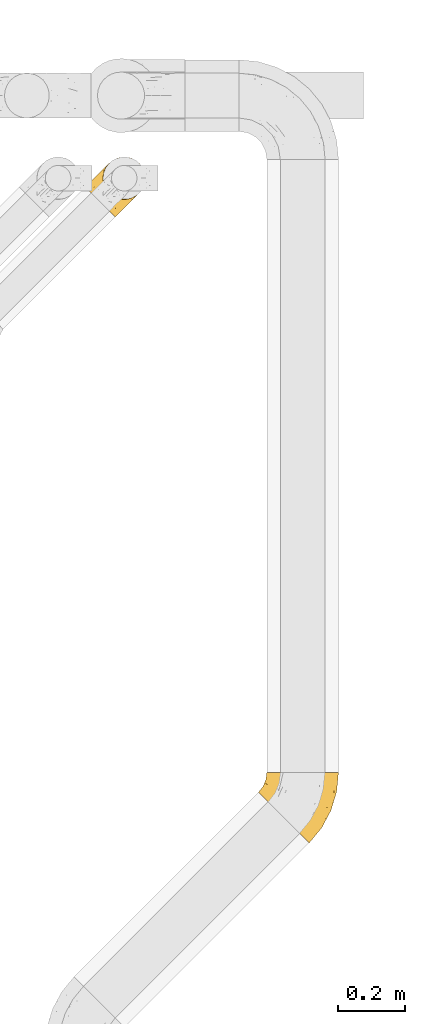
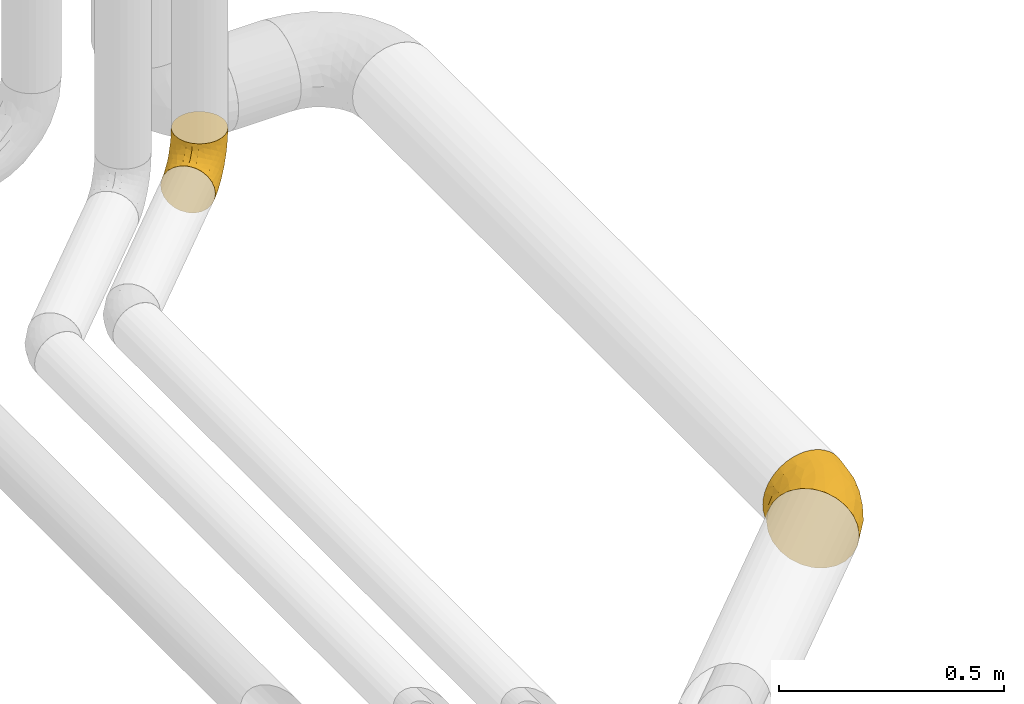
# One storey, part 36 of 93: 2 coverings.
"""IFC2X3 building model written with IfcOpenShell, lengths in millimetres."""

from ifc_helpers import new_model, entity, si_unit, converted_unit, derived_unit, direction, frame, origin, place, context, subcontext, project, spatial, faceted_brep, element, save


model = new_model("IFC2X3")

# Units and contexts
model_context = context("Model", 3, precision=0.01, world=origin(), true_north=direction((6.12303176911189e-17, 1.0)))
body_context = subcontext(model_context, "Body", "Model", "MODEL_VIEW")
ifc_project = project(units=[si_unit("LENGTHUNIT", "METRE", prefix="MILLI"), si_unit("AREAUNIT", "SQUARE_METRE"), si_unit("VOLUMEUNIT", "CUBIC_METRE"), converted_unit("PLANEANGLEUNIT", "DEGREE", entity("IfcRatioMeasure", 0.0174532925199433), si_unit("PLANEANGLEUNIT", "RADIAN"), dimensions=[0, 0, 0, 0, 0, 0, 0]), si_unit("MASSUNIT", "GRAM", prefix="KILO"), derived_unit("MASSDENSITYUNIT", [(si_unit("MASSUNIT", "GRAM", prefix="KILO"), 1), (si_unit("LENGTHUNIT", "METRE"), -3)]), derived_unit("MOMENTOFINERTIAUNIT", [(si_unit("LENGTHUNIT", "METRE"), 4)]), si_unit("TIMEUNIT", "SECOND"), si_unit("FREQUENCYUNIT", "HERTZ"), si_unit("THERMODYNAMICTEMPERATUREUNIT", "DEGREE_CELSIUS"), derived_unit("THERMALTRANSMITTANCEUNIT", [(si_unit("MASSUNIT", "GRAM", prefix="KILO"), 1), (si_unit("THERMODYNAMICTEMPERATUREUNIT", "KELVIN"), -1), (si_unit("TIMEUNIT", "SECOND"), -3)]), derived_unit("VOLUMETRICFLOWRATEUNIT", [(si_unit("LENGTHUNIT", "METRE"), 3), (si_unit("TIMEUNIT", "SECOND"), -1)]), derived_unit("MASSFLOWRATEUNIT", [(si_unit("MASSUNIT", "GRAM", prefix="KILO"), 1), (si_unit("TIMEUNIT", "SECOND"), -1)]), derived_unit("ROTATIONALFREQUENCYUNIT", [(si_unit("TIMEUNIT", "SECOND"), -1)]), si_unit("ELECTRICCURRENTUNIT", "AMPERE"), si_unit("ELECTRICVOLTAGEUNIT", "VOLT"), si_unit("POWERUNIT", "WATT"), si_unit("FORCEUNIT", "NEWTON", prefix="KILO"), si_unit("ILLUMINANCEUNIT", "LUX"), si_unit("LUMINOUSFLUXUNIT", "LUMEN"), si_unit("LUMINOUSINTENSITYUNIT", "CANDELA"), derived_unit("USERDEFINED", [(si_unit("MASSUNIT", "GRAM", prefix="KILO"), -1), (si_unit("LENGTHUNIT", "METRE"), -2), (si_unit("TIMEUNIT", "SECOND"), 3), (si_unit("LUMINOUSFLUXUNIT", "LUMEN"), 1)]), derived_unit("LINEARVELOCITYUNIT", [(si_unit("LENGTHUNIT", "METRE"), 1), (si_unit("TIMEUNIT", "SECOND"), -1)]), si_unit("PRESSUREUNIT", "PASCAL"), derived_unit("USERDEFINED", [(si_unit("LENGTHUNIT", "METRE"), -2), (si_unit("MASSUNIT", "GRAM", prefix="KILO"), 1), (si_unit("TIMEUNIT", "SECOND"), -2)]), derived_unit("LINEARFORCEUNIT", [(si_unit("MASSUNIT", "GRAM", prefix="KILO"), 1), (si_unit("LENGTHUNIT", "METRE"), 1), (si_unit("TIMEUNIT", "SECOND"), -2), (si_unit("LENGTHUNIT", "METRE"), -1)]), derived_unit("PLANARFORCEUNIT", [(si_unit("MASSUNIT", "GRAM", prefix="KILO"), 1), (si_unit("LENGTHUNIT", "METRE"), 1), (si_unit("TIMEUNIT", "SECOND"), -2), (si_unit("LENGTHUNIT", "METRE"), -2)])], contexts=[model_context])

# Site, building, storey
site_placement = place(None, origin())
site = spatial("IfcSite", under=ifc_project, at=site_placement, CompositionType="ELEMENT")
building_placement = place(site_placement, origin())
building = spatial("IfcBuilding", under=site, at=building_placement, CompositionType="ELEMENT")
storey_placement = place(building_placement, frame((0.0, 0.0, -4200.0)))
storey = spatial("IfcBuildingStorey", under=building, at=storey_placement, CompositionType="ELEMENT", Elevation=-4200.0)

# Coverings
covering_1_placement = place(storey_placement, frame((25506.57, 10093.02, 2891.9)))
element("IfcCovering", 1, at=covering_1_placement, inside=storey, Name=":ADSK_", ObjectType=":ADSK_", PredefinedType="INSULATION", context=body_context, shape_type="Brep", body=[
    faceted_brep([(37.66, 211.25, 156.45), (46.39, 211.25, 170.7), (57.25, 211.25, 183.4), (69.95, 211.25, 194.26), (84.2, 211.25, 202.99), (99.64, 211.25, 209.38), (115.89, 211.25, 213.28), (132.55, 211.25, 214.6), (149.22, 211.25, 213.28), (165.47, 211.25, 209.38), (180.91, 211.25, 202.99), (195.15, 211.25, 194.25), (207.86, 211.25, 183.4), (218.71, 211.25, 170.69), (227.44, 211.25, 156.45), (233.84, 211.25, 141.01), (237.74, 211.25, 124.76), (239.05, 211.25, 108.1), (237.74, 211.25, 91.43), (233.84, 211.25, 75.18), (227.44, 211.25, 59.74), (218.71, 211.25, 45.49), (207.86, 211.25, 32.79), (195.15, 211.25, 21.93), (180.9, 211.25, 13.2), (165.46, 211.25, 6.81), (149.21, 211.25, 2.91), (132.55, 211.25, 1.6), (115.89, 211.25, 2.91), (99.64, 211.25, 6.81), (84.2, 211.25, 13.21), (69.95, 211.25, 21.94), (57.24, 211.25, 32.79), (46.39, 211.25, 45.5), (37.66, 211.25, 59.74), (31.26, 211.25, 75.18), (27.36, 211.25, 91.43), (26.05, 211.25, 108.1), (27.36, 211.25, 124.76), (31.27, 211.25, 141.01), (1.6, 152.21, 108.1), (4.16, 149.64, 80.53), (11.68, 142.12, 54.85), (23.65, 130.15, 32.79), (39.25, 114.56, 15.86), (57.41, 96.39, 5.22), (76.9, 76.9, 1.6), (96.39, 57.41, 5.22), (114.56, 39.25, 15.86), (130.15, 23.65, 32.79), (142.12, 11.68, 54.85), (149.64, 4.16, 80.53), (152.21, 1.6, 108.1), (149.64, 4.16, 135.66), (142.12, 11.68, 161.35), (130.15, 23.65, 183.4), (114.56, 39.25, 200.33), (96.39, 57.41, 210.97), (76.9, 76.9, 214.6), (57.41, 96.39, 210.97), (39.25, 114.56, 200.33), (23.65, 130.15, 183.4), (11.68, 142.12, 161.35), (4.16, 149.64, 135.66), (200.63, 72.7, 135.49), (189.08, 46.53, 108.1), (216.48, 97.79, 108.1), (225.14, 151.09, 147.54), (224.66, 126.02, 127.59), (203.85, 103.93, 160.91), (184.62, 95.96, 180.48), (174.13, 56.47, 167.28), (208.26, 151.24, 175.57), (188.26, 163.53, 195.88), (145.0, 147.35, 212.24), (122.46, 102.43, 212.65), (144.65, 102.26, 206.95), (169.75, 156.96, 205.26), (118.09, 138.54, 214.6), (100.53, 105.69, 214.6), (153.71, 66.85, 191.83), (128.9, 174.19, 214.6), (233.35, 153.41, 108.1), (173.63, 116.59, 196.28), (75.61, 126.11, 209.66), (100.85, 155.5, 212.26), (78.92, 160.56, 204.85), (53.32, 141.97, 196.53), (65.14, 186.68, 192.48), (41.13, 188.55, 166.83), (49.52, 171.02, 182.99), (96.52, 181.83, 209.27), (32.64, 151.73, 176.02), (21.83, 178.42, 130.14), (23.21, 189.64, 108.1), (14.86, 169.5, 108.1), (28.58, 174.54, 153.23), (63.21, 165.87, 195.33), (21.83, 178.42, 86.05), (68.93, 185.87, 20.86), (62.27, 161.66, 20.39), (51.64, 183.46, 34.97), (82.06, 152.23, 8.81), (96.93, 173.91, 6.26), (28.58, 174.54, 62.96), (38.25, 155.81, 37.12), (48.99, 137.53, 20.47), (96.59, 137.92, 3.38), (118.09, 138.54, 1.6), (76.16, 126.61, 6.47), (100.53, 105.69, 1.6), (128.9, 174.19, 1.6), (131.79, 112.92, 4.17), (220.0, 129.96, 69.12), (195.21, 106.6, 41.95), (212.72, 157.34, 44.59), (168.72, 53.94, 44.6), (132.03, 76.09, 10.55), (154.58, 160.77, 5.33), (201.13, 72.5, 82.82), (162.25, 77.86, 25.33), (179.31, 48.81, 64.4), (224.88, 125.92, 89.94), (196.95, 152.51, 28.79), (173.66, 165.09, 11.88), (159.49, 119.29, 11.86)], [[[0, 1, 2, 3, 4, 5, 6, 7, 8, 9, 10, 11, 12, 13, 14, 15, 16, 17, 18, 19, 20, 21, 22, 23, 24, 25, 26, 27, 28, 29, 30, 31, 32, 33, 34, 35, 36, 37, 38, 39]], [[40, 41, 42, 43, 44, 45, 46, 47, 48, 49, 50, 51, 52, 53, 54, 55, 56, 57, 58, 59, 60, 61, 62, 63]], [[64, 65, 66]], [[65, 53, 52]], [[67, 68, 16]], [[67, 69, 64]], [[69, 70, 71]], [[68, 64, 66]], [[67, 72, 69]], [[69, 72, 70]], [[72, 73, 70]], [[74, 9, 8]], [[75, 58, 57]], [[76, 77, 74]], [[74, 77, 9]], [[78, 79, 75]], [[55, 71, 80]], [[76, 74, 75]], [[81, 78, 74]], [[73, 12, 11]], [[80, 76, 56]], [[13, 12, 72]], [[68, 66, 82]], [[76, 83, 77]], [[72, 67, 13]], [[67, 14, 13]], [[64, 68, 67]], [[73, 72, 12]], [[16, 15, 67]], [[16, 82, 17]], [[76, 80, 83]], [[64, 71, 54]], [[54, 53, 64]], [[71, 70, 80]], [[74, 8, 81]], [[7, 81, 8]], [[74, 78, 75]], [[53, 65, 64]], [[77, 10, 9]], [[83, 73, 77]], [[71, 55, 54]], [[80, 70, 83]], [[10, 77, 73]], [[56, 76, 57]], [[16, 68, 82]], [[15, 14, 67]], [[55, 80, 56]], [[64, 69, 71]], [[73, 83, 70]], [[10, 73, 11]], [[58, 75, 79]], [[57, 76, 75]], [[78, 84, 79]], [[59, 58, 79]], [[85, 84, 78]], [[84, 86, 87]], [[59, 79, 84]], [[60, 87, 61]], [[84, 85, 86]], [[88, 89, 90]], [[85, 91, 86]], [[61, 92, 62]], [[93, 94, 95]], [[38, 93, 39]], [[84, 87, 60]], [[95, 40, 63]], [[63, 96, 93]], [[63, 93, 95]], [[62, 96, 63]], [[97, 88, 90]], [[81, 91, 85]], [[81, 85, 78]], [[4, 88, 91]], [[3, 88, 4]], [[6, 91, 81]], [[89, 88, 2]], [[93, 96, 39]], [[5, 91, 6]], [[7, 6, 81]], [[91, 88, 86]], [[92, 89, 96]], [[97, 86, 88]], [[89, 2, 1]], [[37, 94, 38]], [[93, 38, 94]], [[60, 59, 84]], [[90, 92, 87]], [[0, 89, 1]], [[2, 88, 3]], [[39, 89, 0]], [[89, 39, 96]], [[96, 62, 92]], [[92, 90, 89]], [[5, 4, 91]], [[90, 87, 97]], [[87, 92, 61]], [[87, 86, 97]], [[98, 41, 95]], [[99, 100, 101]], [[94, 98, 95]], [[102, 99, 103]], [[104, 105, 42]], [[95, 41, 40]], [[34, 101, 104]], [[101, 105, 104]], [[105, 106, 43]], [[107, 103, 108]], [[44, 109, 45]], [[46, 45, 110]], [[45, 109, 110]], [[101, 100, 105]], [[106, 100, 102]], [[107, 110, 109]], [[106, 109, 44]], [[100, 99, 102]], [[35, 98, 36]], [[30, 103, 99]], [[44, 43, 106]], [[34, 104, 35]], [[98, 35, 104]], [[101, 34, 33]], [[41, 104, 42]], [[99, 101, 32]], [[31, 99, 32]], [[108, 103, 111]], [[33, 32, 101]], [[109, 102, 107]], [[29, 103, 30]], [[106, 105, 100]], [[103, 29, 111]], [[41, 98, 104]], [[43, 42, 105]], [[28, 27, 111]], [[29, 28, 111]], [[30, 99, 31]], [[36, 98, 94]], [[103, 107, 102]], [[36, 94, 37]], [[110, 107, 108]], [[106, 102, 109]], [[112, 47, 46]], [[113, 114, 115]], [[20, 115, 21]], [[112, 46, 110]], [[50, 49, 116]], [[47, 117, 48]], [[26, 118, 111]], [[108, 112, 110]], [[66, 65, 119]], [[120, 114, 116]], [[65, 52, 51]], [[51, 121, 119]], [[121, 116, 114]], [[119, 121, 113]], [[113, 122, 119]], [[48, 120, 49]], [[23, 123, 124]], [[116, 121, 50]], [[114, 113, 121]], [[19, 18, 122]], [[25, 118, 26]], [[120, 116, 49]], [[125, 112, 118]], [[119, 122, 66]], [[123, 120, 125]], [[118, 124, 125]], [[22, 21, 115]], [[121, 51, 50]], [[65, 51, 119]], [[23, 22, 123]], [[117, 120, 48]], [[22, 115, 123]], [[123, 115, 114]], [[113, 20, 19]], [[25, 24, 124]], [[122, 82, 66]], [[18, 17, 82]], [[120, 123, 114]], [[112, 125, 117]], [[122, 18, 82]], [[123, 125, 124]], [[115, 20, 113]], [[118, 112, 108]], [[26, 111, 27]], [[122, 113, 19]], [[118, 108, 111]], [[25, 124, 118]], [[124, 24, 23]], [[112, 117, 47]], [[120, 117, 125]]]),
])
covering_2_placement = place(storey_placement, frame((24991.87, 11953.15, 2935.4)))
element("IfcCovering", 2, at=covering_2_placement, inside=storey, Name=":ADSK_", ObjectType=":ADSK_", PredefinedType="INSULATION", context=body_context, shape_type="Brep", body=[
    faceted_brep([(170.2, 83.34, 164.6), (176.32, 96.04, 164.6), (179.46, 109.8, 164.6), (179.46, 123.9, 164.6), (176.32, 137.66, 164.6), (170.2, 150.37, 164.6), (161.4, 161.4, 164.6), (150.37, 170.2, 164.6), (137.66, 176.32, 164.6), (123.91, 179.46, 164.6), (109.8, 179.46, 164.6), (96.05, 176.32, 164.6), (83.34, 170.2, 164.6), (72.31, 161.4, 164.6), (63.51, 150.37, 164.6), (57.39, 137.66, 164.6), (54.25, 123.91, 164.6), (54.25, 109.8, 164.6), (57.39, 96.05, 164.6), (63.51, 83.34, 164.6), (72.31, 72.31, 164.6), (83.34, 63.51, 164.6), (96.04, 57.39, 164.6), (109.8, 54.25, 164.6), (123.9, 54.25, 164.6), (137.66, 57.39, 164.6), (150.37, 63.51, 164.6), (161.4, 72.31, 164.6), (7.56, 84.72, 96.1), (3.11, 89.17, 80.9), (2.64, 89.65, 75.83), (1.6, 90.69, 64.6), (3.11, 89.17, 48.29), (7.56, 84.72, 33.1), (14.64, 77.64, 20.05), (23.87, 68.42, 10.04), (34.61, 57.67, 3.74), (46.14, 46.14, 1.6), (57.67, 34.61, 3.74), (68.42, 23.87, 10.04), (77.64, 14.64, 20.05), (84.72, 7.56, 33.1), (89.17, 3.11, 48.29), (90.69, 1.6, 64.6), (89.65, 2.64, 75.83), (89.17, 3.11, 80.9), (84.72, 7.56, 96.1), (77.64, 14.64, 109.14), (68.42, 23.87, 119.15), (57.67, 34.61, 125.45), (46.14, 46.14, 127.6), (34.61, 57.67, 125.45), (23.87, 68.42, 119.15), (14.64, 77.64, 109.14), (92.67, 41.05, 16.11), (89.38, 58.08, 10.47), (114.72, 66.35, 25.17), (73.84, 57.85, 5.03), (75.97, 75.97, 7.15), (164.16, 94.73, 89.92), (150.24, 84.82, 63.64), (155.13, 105.66, 69.58), (128.48, 100.83, 37.4), (103.77, 103.77, 23.43), (127.64, 127.64, 49.34), (132.1, 49.93, 57.66), (115.76, 38.13, 41.13), (130.83, 62.77, 43.56), (112.06, 26.69, 51.24), (128.21, 40.61, 67.11), (169.64, 111.23, 101.38), (166.05, 124.65, 96.89), (174.42, 129.91, 127.01), (109.63, 77.65, 20.7), (95.36, 79.57, 13.5), (107.56, 40.52, 28.72), (157.47, 157.47, 122.41), (169.3, 142.46, 125.37), (148.08, 125.06, 67.01), (158.77, 139.5, 94.82), (153.98, 77.33, 76.34), (166.46, 78.84, 138.01), (172.41, 90.38, 133.22), (132.25, 43.16, 83.69), (122.4, 33.3, 76.59), (112.54, 23.45, 69.49), (146.96, 60.49, 83.16), (177.46, 117.32, 133.67), (173.91, 102.46, 119.86), (135.86, 81.91, 43.48), (147.9, 58.8, 105.82), (140.08, 50.98, 94.76), (159.87, 70.78, 150.96), (157.94, 68.85, 133.69), (158.88, 71.28, 110.48), (152.92, 63.82, 119.76), (162.84, 80.67, 101.13), (145.96, 145.96, 83.1), (100.33, 11.24, 66.76), (75.99, 54.76, 136.91), (92.06, 52.75, 142.02), (81.36, 61.52, 150.15), (100.35, 13.29, 79.29), (107.79, 26.26, 96.09), (120.38, 32.9, 87.81), (119.61, 35.82, 99.92), (108.27, 21.64, 83.57), (92.44, 45.49, 131.18), (109.09, 42.06, 123.5), (104.37, 47.78, 135.55), (121.9, 53.26, 152.5), (107.87, 52.21, 147.78), (125.77, 51.13, 137.69), (129.48, 44.31, 106.96), (120.16, 42.34, 116.2), (83.38, 39.36, 124.83), (72.12, 33.6, 122.46), (91.0, 27.71, 112.17), (96.5, 17.02, 94.66), (67.98, 45.96, 128.78), (52.68, 52.68, 130.07), (139.06, 56.71, 144.19), (149.41, 61.85, 137.7), (150.1, 63.05, 150.62), (68.8, 68.8, 146.1), (128.78, 47.98, 121.85), (138.08, 51.11, 112.08), (140.29, 54.54, 124.43), (71.05, 71.05, 157.98), (107.6, 34.23, 110.72), (97.13, 36.92, 119.91), (117.73, 47.07, 130.41), (92.73, 57.22, 153.66), (64.01, 64.01, 139.32), (59.22, 59.22, 132.55), (95.09, 22.22, 103.35), (27.71, 91.0, 112.17), (42.34, 120.17, 116.21), (34.23, 107.62, 110.7), (42.06, 109.09, 123.5), (45.96, 67.97, 128.77), (11.24, 100.33, 66.76), (61.52, 81.36, 150.15), (54.76, 76.0, 136.91), (51.13, 125.77, 137.69), (54.55, 140.3, 124.43), (47.98, 128.79, 121.85), (43.16, 132.25, 83.69), (33.3, 122.4, 76.59), (32.89, 120.37, 87.81), (47.07, 117.73, 130.41), (21.64, 108.27, 83.57), (26.26, 107.79, 96.09), (22.22, 95.09, 103.35), (33.6, 72.12, 122.46), (17.02, 96.5, 94.66), (13.29, 100.35, 79.29), (47.78, 104.37, 135.54), (45.49, 92.44, 131.17), (52.75, 92.06, 142.02), (57.22, 92.73, 153.66), (36.91, 97.13, 119.89), (70.78, 159.87, 150.96), (52.21, 107.88, 147.78), (51.11, 138.09, 112.07), (44.31, 129.47, 106.97), (56.71, 139.07, 144.19), (53.26, 121.9, 152.5), (39.36, 83.38, 124.83), (68.85, 157.94, 133.69), (63.05, 150.11, 150.62), (61.86, 149.41, 137.71), (50.98, 140.08, 94.76), (35.82, 119.62, 99.9), (63.82, 152.92, 119.76), (58.8, 147.9, 105.82), (23.45, 112.54, 69.49), (66.35, 114.72, 25.17), (41.05, 92.67, 16.11), (40.52, 107.56, 28.72), (38.13, 115.76, 41.13), (58.08, 89.38, 10.47), (77.95, 93.76, 12.64), (57.83, 73.77, 5.01), (40.61, 128.21, 67.11), (78.84, 166.46, 138.01), (90.39, 172.42, 133.22), (80.67, 162.84, 101.13), (84.82, 150.24, 63.64), (94.74, 164.16, 89.92), (105.66, 155.12, 69.57), (71.28, 158.88, 110.48), (60.49, 146.96, 83.16), (26.69, 112.06, 51.24), (79.75, 110.57, 21.38), (111.24, 169.64, 101.38), (117.33, 177.46, 133.67), (124.66, 166.05, 96.89), (131.19, 175.82, 135.87), (102.47, 173.91, 119.86), (62.77, 130.83, 43.56), (125.06, 148.08, 67.01), (100.83, 128.48, 37.4), (77.34, 153.99, 76.35), (49.93, 132.1, 57.66), (81.91, 135.86, 43.48), (142.47, 169.3, 125.37), (137.22, 160.06, 94.76), (94.75, 110.98, 23.91)], [[[0, 1, 2, 3, 4, 5, 6, 7, 8, 9, 10, 11, 12, 13, 14, 15, 16, 17, 18, 19, 20, 21, 22, 23, 24, 25, 26, 27]], [[28, 29, 30, 31, 32, 33, 34, 35, 36, 37, 38, 39, 40, 41, 42, 43, 44, 45, 46, 47, 48, 49, 50, 51, 52, 53]], [[54, 55, 56]], [[57, 37, 58]], [[59, 60, 61]], [[62, 63, 64]], [[65, 66, 67]], [[68, 65, 69]], [[70, 71, 72]], [[55, 73, 56]], [[39, 38, 55]], [[55, 74, 73]], [[75, 40, 54]], [[40, 39, 54]], [[76, 5, 77]], [[71, 78, 79]], [[41, 75, 66]], [[42, 68, 43]], [[59, 80, 60]], [[0, 81, 82]], [[69, 83, 84, 85]], [[69, 86, 83]], [[82, 1, 0]], [[2, 87, 3]], [[4, 3, 72]], [[40, 75, 41]], [[5, 4, 77]], [[2, 1, 88]], [[72, 3, 87]], [[5, 76, 6]], [[70, 87, 88]], [[68, 66, 65]], [[87, 2, 88]], [[56, 89, 67]], [[78, 62, 64]], [[86, 90, 91, 83]], [[81, 27, 92, 93]], [[62, 61, 89]], [[94, 93, 95, 90]], [[96, 94, 86]], [[38, 57, 55]], [[78, 61, 62]], [[82, 88, 1]], [[78, 64, 97]], [[57, 74, 55]], [[76, 77, 79]], [[77, 72, 71]], [[80, 86, 65]], [[94, 81, 93]], [[96, 88, 82]], [[79, 78, 97]], [[61, 71, 70]], [[86, 94, 90]], [[81, 96, 82]], [[68, 85, 98, 43]], [[86, 69, 65]], [[68, 69, 85]], [[66, 42, 41]], [[66, 68, 42]], [[67, 66, 75]], [[56, 67, 75]], [[67, 60, 80]], [[59, 70, 88]], [[70, 59, 61]], [[60, 67, 89]], [[78, 71, 61]], [[81, 94, 96]], [[27, 81, 0]], [[88, 96, 59]], [[80, 59, 96]], [[86, 80, 96]], [[67, 80, 65]], [[62, 89, 56]], [[61, 60, 89]], [[55, 54, 39]], [[75, 54, 56]], [[37, 57, 38]], [[74, 57, 58]], [[58, 63, 74]], [[62, 74, 63]], [[74, 62, 73]], [[62, 56, 73]], [[4, 72, 77]], [[70, 72, 87]], [[76, 79, 97]], [[71, 79, 77]], [[99, 100, 101]], [[98, 85, 102]], [[103, 104, 105]], [[106, 102, 85]], [[107, 108, 109]], [[106, 85, 84]], [[110, 111, 112]], [[105, 113, 114]], [[115, 116, 117]], [[47, 46, 118]], [[49, 119, 120]], [[48, 47, 117]], [[121, 122, 123]], [[123, 92, 26]], [[48, 116, 49]], [[124, 99, 101]], [[125, 126, 127]], [[127, 121, 112]], [[25, 24, 121]], [[101, 128, 124]], [[117, 129, 130]], [[26, 25, 123]], [[27, 26, 92]], [[131, 109, 108]], [[127, 95, 122]], [[24, 110, 121]], [[21, 20, 128]], [[131, 108, 114]], [[44, 43, 98, 45]], [[129, 114, 108]], [[23, 110, 24]], [[119, 115, 99]], [[101, 132, 21]], [[111, 23, 22]], [[90, 126, 91]], [[99, 124, 133, 134]], [[132, 111, 22]], [[128, 101, 21]], [[135, 47, 118]], [[101, 100, 132]], [[119, 99, 134]], [[107, 99, 115]], [[125, 114, 113]], [[93, 123, 122]], [[112, 125, 127]], [[129, 105, 114]], [[127, 90, 95]], [[120, 50, 49]], [[116, 119, 49]], [[111, 110, 23]], [[121, 110, 112]], [[111, 132, 100]], [[21, 132, 22]], [[125, 112, 131]], [[126, 125, 113]], [[112, 111, 131]], [[109, 111, 100]], [[111, 109, 131]], [[107, 109, 100]], [[99, 107, 100]], [[107, 115, 130]], [[126, 113, 91]], [[90, 127, 126]], [[131, 114, 125]], [[130, 129, 108]], [[135, 129, 117]], [[129, 103, 105]], [[107, 130, 108]], [[117, 130, 115]], [[121, 123, 25]], [[92, 123, 93]], [[127, 122, 121]], [[95, 93, 122]], [[117, 116, 48]], [[119, 116, 115]], [[84, 104, 106]], [[83, 113, 105]], [[103, 118, 106]], [[105, 104, 83]], [[102, 46, 45]], [[106, 104, 103]], [[83, 104, 84]], [[118, 103, 135]], [[102, 118, 46]], [[129, 135, 103]], [[47, 135, 117]], [[102, 106, 118]], [[98, 102, 45]], [[113, 83, 91]], [[119, 134, 120]], [[53, 52, 136]], [[137, 138, 139]], [[51, 120, 140]], [[141, 31, 30, 29]], [[19, 142, 128]], [[143, 134, 133, 124]], [[144, 145, 146]], [[147, 148, 149]], [[150, 144, 146]], [[151, 152, 149]], [[153, 53, 136]], [[52, 154, 136]], [[28, 155, 156]], [[143, 140, 134]], [[157, 158, 159]], [[124, 142, 143]], [[124, 128, 142]], [[18, 160, 19]], [[138, 161, 139]], [[14, 13, 162]], [[156, 141, 29]], [[159, 160, 163]], [[18, 17, 163]], [[164, 165, 146]], [[51, 154, 52]], [[166, 145, 144]], [[157, 163, 150]], [[166, 144, 167]], [[167, 17, 16]], [[16, 15, 166]], [[136, 168, 161]], [[162, 169, 170]], [[15, 14, 170]], [[167, 163, 17]], [[19, 128, 20]], [[171, 145, 166]], [[160, 159, 142]], [[155, 153, 152]], [[170, 166, 15]], [[142, 159, 143]], [[158, 143, 159]], [[140, 143, 168]], [[154, 140, 168]], [[164, 172, 165]], [[138, 173, 152]], [[150, 146, 137]], [[166, 170, 171]], [[174, 175, 145]], [[166, 167, 16]], [[163, 167, 144]], [[19, 160, 142]], [[163, 160, 18]], [[164, 146, 145]], [[137, 146, 165]], [[157, 150, 139]], [[163, 144, 150]], [[139, 161, 158]], [[163, 157, 159]], [[139, 158, 157]], [[143, 158, 168]], [[145, 175, 164]], [[120, 51, 50]], [[173, 138, 137]], [[150, 137, 139]], [[173, 137, 165]], [[153, 138, 152]], [[136, 161, 138]], [[158, 161, 168]], [[162, 170, 14]], [[170, 169, 171]], [[169, 174, 171]], [[145, 171, 174]], [[140, 154, 51]], [[136, 154, 168]], [[165, 147, 173]], [[173, 149, 152]], [[156, 151, 176]], [[151, 148, 176]], [[155, 152, 151]], [[147, 149, 173]], [[151, 149, 148]], [[156, 155, 151]], [[53, 155, 28]], [[53, 153, 155]], [[138, 153, 136]], [[141, 156, 176]], [[28, 156, 29]], [[172, 164, 175]], [[172, 147, 165]], [[120, 134, 140]], [[177, 178, 179]], [[33, 32, 180]], [[181, 182, 183]], [[184, 176, 148, 147]], [[185, 186, 187]], [[188, 189, 190]], [[191, 192, 175]], [[184, 193, 176]], [[194, 181, 177]], [[193, 180, 32]], [[37, 36, 183]], [[195, 196, 197]], [[9, 8, 198]], [[178, 181, 35]], [[36, 35, 181]], [[33, 179, 34]], [[189, 199, 195]], [[193, 31, 141, 176]], [[35, 34, 178]], [[186, 11, 199]], [[192, 147, 172, 175]], [[179, 180, 200]], [[201, 64, 202]], [[179, 200, 177]], [[13, 12, 185]], [[203, 187, 189]], [[12, 11, 186]], [[184, 192, 204]], [[203, 192, 187]], [[10, 199, 11]], [[177, 200, 205]], [[206, 198, 8]], [[207, 201, 197]], [[63, 208, 64]], [[7, 206, 8]], [[194, 182, 181]], [[7, 6, 76]], [[199, 196, 195]], [[196, 10, 9]], [[197, 196, 198]], [[7, 76, 206]], [[10, 196, 199]], [[207, 76, 97]], [[191, 175, 174, 169]], [[64, 201, 97]], [[63, 58, 182]], [[199, 187, 186]], [[187, 191, 185]], [[177, 205, 202]], [[207, 197, 206]], [[192, 184, 147]], [[193, 184, 204]], [[193, 204, 180]], [[31, 193, 32]], [[204, 203, 200]], [[33, 180, 179]], [[204, 200, 180]], [[200, 188, 205]], [[191, 169, 185]], [[192, 191, 187]], [[190, 195, 197]], [[195, 190, 189]], [[197, 201, 190]], [[202, 190, 201]], [[185, 169, 162, 13]], [[186, 185, 12]], [[203, 189, 188]], [[187, 199, 189]], [[200, 203, 188]], [[192, 203, 204]], [[188, 190, 205]], [[202, 205, 190]], [[179, 178, 34]], [[181, 178, 177]], [[177, 202, 194]], [[182, 208, 63]], [[182, 194, 208]], [[183, 182, 58]], [[37, 183, 58]], [[181, 183, 36]], [[194, 202, 208]], [[64, 208, 202]], [[197, 198, 206]], [[9, 198, 196]], [[76, 207, 206]], [[97, 201, 207]]]),
])

save(model, "model.ifc")
